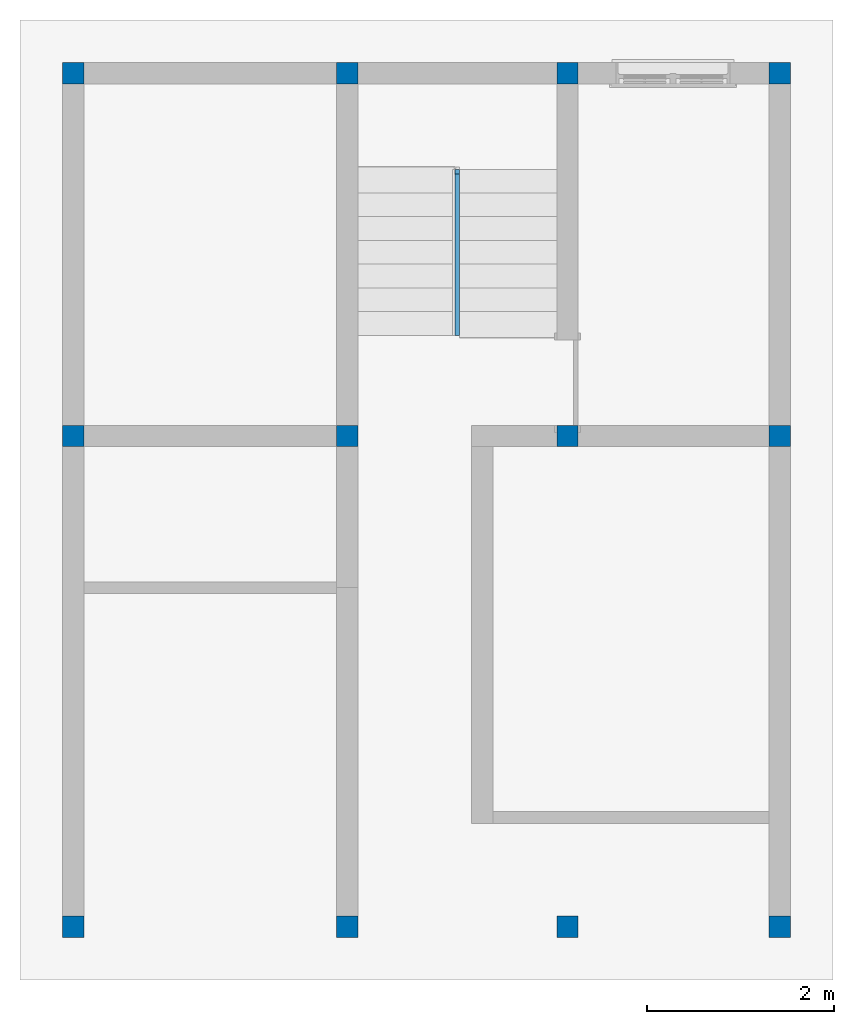
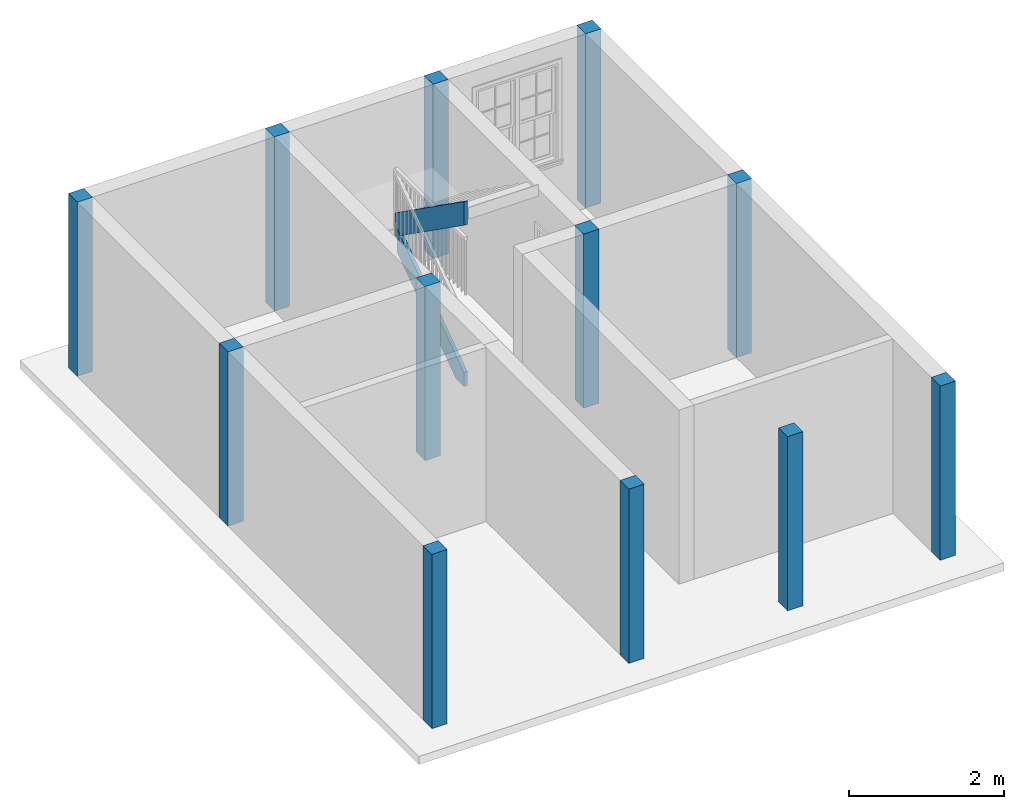
# One storey, part 1 of 6: 12 columns, 2 members, 1 element without a shape of its own.
"""IFC2X3 building model written with IfcOpenShell, lengths in feet."""

from ifc_helpers import new_model, entity, si_unit, converted_unit, derived_unit, direction, frame, origin, origin_2d_with_axis, place, context, subcontext, project, spatial, polyline, rectangle, outline, extrude, source, transform, mapped, material, type_object, type_shapes, element, aggregate, save


model = new_model("IFC2X3")

# Units and contexts
model_context = context("Model", 3, precision=0.0001, world=origin(), true_north=direction((6.123031769111886e-17, 1.0)))
body_context = subcontext(model_context, "Body", "Model", "MODEL_VIEW")
ifc_project = project(units=[converted_unit("LENGTHUNIT", "FOOT", entity("IfcLengthMeasure", 0.3048), si_unit("LENGTHUNIT", "METRE"), dimensions=[1, 0, 0, 0, 0, 0, 0]), converted_unit("AREAUNIT", "SQUARE FOOT", entity("IfcAreaMeasure", 0.09290304), si_unit("AREAUNIT", "SQUARE_METRE"), dimensions=[2, 0, 0, 0, 0, 0, 0]), converted_unit("VOLUMEUNIT", "CUBIC FOOT", entity("IfcVolumeMeasure", 0.028316846592000004), si_unit("VOLUMEUNIT", "CUBIC_METRE"), dimensions=[3, 0, 0, 0, 0, 0, 0]), converted_unit("PLANEANGLEUNIT", "DEGREE", entity("IfcPlaneAngleMeasure", 0.017453292519943278), si_unit("PLANEANGLEUNIT", "RADIAN"), dimensions=[0, 0, 0, 0, 0, 0, 0]), si_unit("MASSUNIT", "GRAM", prefix="KILO"), derived_unit("MASSDENSITYUNIT", [(si_unit("MASSUNIT", "GRAM", prefix="KILO"), 1), (si_unit("LENGTHUNIT", "METRE"), -3)]), derived_unit("IONCONCENTRATIONUNIT", [(si_unit("MASSUNIT", "GRAM", prefix="KILO"), 1), (si_unit("LENGTHUNIT", "METRE"), -3)]), derived_unit("MOMENTOFINERTIAUNIT", [(si_unit("LENGTHUNIT", "METRE"), 4)]), si_unit("TIMEUNIT", "SECOND"), si_unit("FREQUENCYUNIT", "HERTZ"), si_unit("THERMODYNAMICTEMPERATUREUNIT", "DEGREE_CELSIUS"), derived_unit("THERMALTRANSMITTANCEUNIT", [(si_unit("MASSUNIT", "GRAM", prefix="KILO"), 1), (si_unit("THERMODYNAMICTEMPERATUREUNIT", "KELVIN"), -1), (si_unit("TIMEUNIT", "SECOND"), -3)]), derived_unit("THERMALCONDUCTANCEUNIT", [(si_unit("MASSUNIT", "GRAM", prefix="KILO"), 1), (si_unit("THERMODYNAMICTEMPERATUREUNIT", "KELVIN"), -1), (si_unit("TIMEUNIT", "SECOND"), -3), (si_unit("LENGTHUNIT", "METRE"), 1)]), derived_unit("VOLUMETRICFLOWRATEUNIT", [(si_unit("LENGTHUNIT", "METRE"), 3), (si_unit("TIMEUNIT", "SECOND"), -1)]), derived_unit("MASSFLOWRATEUNIT", [(si_unit("MASSUNIT", "GRAM", prefix="KILO"), 1), (si_unit("TIMEUNIT", "SECOND"), -1)]), derived_unit("ROTATIONALFREQUENCYUNIT", [(si_unit("TIMEUNIT", "SECOND"), -1)]), si_unit("ELECTRICCURRENTUNIT", "AMPERE"), si_unit("ELECTRICVOLTAGEUNIT", "VOLT"), si_unit("POWERUNIT", "WATT"), converted_unit("FORCEUNIT", "KIP", entity("IfcForceMeasure", 2.088543423315013e-05), si_unit("FORCEUNIT", "NEWTON"), dimensions=[1, 1, -2, 0, 0, 0, 0]), si_unit("ILLUMINANCEUNIT", "LUX"), si_unit("LUMINOUSFLUXUNIT", "LUMEN"), si_unit("LUMINOUSINTENSITYUNIT", "CANDELA"), si_unit("ENERGYUNIT", "JOULE"), derived_unit("USERDEFINED", [(si_unit("MASSUNIT", "GRAM", prefix="KILO"), -1), (si_unit("LENGTHUNIT", "METRE"), -2), (si_unit("TIMEUNIT", "SECOND"), 3), (si_unit("LUMINOUSFLUXUNIT", "LUMEN"), 1)]), derived_unit("USERDEFINED", [(si_unit("MASSUNIT", "GRAM", prefix="KILO"), 1), (si_unit("TIMEUNIT", "SECOND"), -3), (si_unit("LENGTHUNIT", "METRE"), 3), (si_unit("ELECTRICCURRENTUNIT", "AMPERE"), -2)]), derived_unit("SOUNDPOWERUNIT", [(si_unit("MASSUNIT", "GRAM", prefix="KILO"), 1), (si_unit("TIMEUNIT", "SECOND"), -3), (si_unit("LENGTHUNIT", "METRE"), 2)]), derived_unit("SOUNDPRESSUREUNIT", [(si_unit("MASSUNIT", "GRAM", prefix="KILO"), 1), (si_unit("LENGTHUNIT", "METRE"), -1), (si_unit("TIMEUNIT", "SECOND"), -2)]), derived_unit("LINEARVELOCITYUNIT", [(si_unit("LENGTHUNIT", "METRE"), 1), (si_unit("TIMEUNIT", "SECOND"), -1)]), si_unit("PRESSUREUNIT", "PASCAL"), derived_unit("USERDEFINED", [(si_unit("MASSUNIT", "GRAM", prefix="KILO"), 1), (si_unit("LENGTHUNIT", "METRE"), -2), (si_unit("TIMEUNIT", "SECOND"), -2)]), derived_unit("LINEARFORCEUNIT", [(si_unit("MASSUNIT", "GRAM", prefix="KILO"), 1), (si_unit("TIMEUNIT", "SECOND"), -2)]), derived_unit("PLANARFORCEUNIT", [(si_unit("MASSUNIT", "GRAM", prefix="KILO"), 1), (si_unit("LENGTHUNIT", "METRE"), -1), (si_unit("TIMEUNIT", "SECOND"), -2)]), derived_unit("SPECIFICHEATCAPACITYUNIT", [(si_unit("THERMODYNAMICTEMPERATUREUNIT", "KELVIN"), -1), (si_unit("LENGTHUNIT", "METRE"), 2), (si_unit("TIMEUNIT", "SECOND"), -2)]), derived_unit("HEATFLUXDENSITYUNIT", [(si_unit("MASSUNIT", "GRAM", prefix="KILO"), 1), (si_unit("TIMEUNIT", "SECOND"), -3)]), derived_unit("HEATINGVALUEUNIT", [(si_unit("LENGTHUNIT", "METRE"), 2), (si_unit("TIMEUNIT", "SECOND"), -2)]), derived_unit("VAPORPERMEABILITYUNIT", [(si_unit("LENGTHUNIT", "METRE"), -1), (si_unit("TIMEUNIT", "SECOND"), 1)]), derived_unit("DYNAMICVISCOSITYUNIT", [(si_unit("MASSUNIT", "GRAM", prefix="KILO"), 1), (si_unit("TIMEUNIT", "SECOND"), -1), (si_unit("LENGTHUNIT", "METRE"), -1)]), derived_unit("THERMALEXPANSIONCOEFFICIENTUNIT", [(si_unit("THERMODYNAMICTEMPERATUREUNIT", "KELVIN"), -1)]), derived_unit("MODULUSOFELASTICITYUNIT", [(si_unit("MASSUNIT", "GRAM", prefix="KILO"), 1), (si_unit("LENGTHUNIT", "METRE"), -1), (si_unit("TIMEUNIT", "SECOND"), -2)]), derived_unit("ISOTHERMALMOISTURECAPACITYUNIT", [(si_unit("LENGTHUNIT", "METRE"), 3), (si_unit("MASSUNIT", "GRAM", prefix="KILO"), -1)]), derived_unit("MOISTUREDIFFUSIVITYUNIT", [(si_unit("TIMEUNIT", "SECOND"), -1), (si_unit("LENGTHUNIT", "METRE"), 2)]), derived_unit("MASSPERLENGTHUNIT", [(si_unit("MASSUNIT", "GRAM", prefix="KILO"), 1), (si_unit("LENGTHUNIT", "METRE"), -1)]), derived_unit("THERMALRESISTANCEUNIT", [(si_unit("MASSUNIT", "GRAM", prefix="KILO"), -1), (si_unit("TIMEUNIT", "SECOND"), 3), (si_unit("THERMODYNAMICTEMPERATUREUNIT", "KELVIN"), 1)]), derived_unit("ACCELERATIONUNIT", [(si_unit("LENGTHUNIT", "METRE"), 1), (si_unit("TIMEUNIT", "SECOND"), -2)]), derived_unit("ANGULARVELOCITYUNIT", [(si_unit("TIMEUNIT", "SECOND"), -1), (si_unit("PLANEANGLEUNIT", "RADIAN"), 1)]), derived_unit("LINEARSTIFFNESSUNIT", [(si_unit("MASSUNIT", "GRAM", prefix="KILO"), 1), (si_unit("TIMEUNIT", "SECOND"), -2)]), derived_unit("WARPINGCONSTANTUNIT", [(si_unit("LENGTHUNIT", "METRE"), 6)]), derived_unit("LINEARMOMENTUNIT", [(si_unit("MASSUNIT", "GRAM", prefix="KILO"), 1), (si_unit("LENGTHUNIT", "METRE"), 1), (si_unit("TIMEUNIT", "SECOND"), -2)]), derived_unit("TORQUEUNIT", [(si_unit("MASSUNIT", "GRAM", prefix="KILO"), 1), (si_unit("LENGTHUNIT", "METRE"), 2), (si_unit("TIMEUNIT", "SECOND"), -2)])], contexts=[model_context])

# Site, building, storey
site_placement = place(None, origin())
site = spatial("IfcSite", under=ifc_project, at=site_placement, CompositionType="ELEMENT")
building_placement = place(site_placement, origin())
building = spatial("IfcBuilding", under=site, at=building_placement, CompositionType="ELEMENT")
storey_placement = place(building_placement, origin())
storey = spatial("IfcBuildingStorey", under=building, at=storey_placement, Name="Level 1", CompositionType="ELEMENT", Elevation=0.0)

# Columns
ifc_material_1 = material(Name="Concrete, Cast-in-Place gray")
column_type = type_object("IfcColumnType", PredefinedType="COLUMN", material=ifc_material_1)
shared_shape = source(origin(), body_context, "Body", "SweptSolid", [
    extrude(rectangle(XDim=0.7499999999999999, YDim=0.7499999999999999, at=origin_2d_with_axis()), frame((0.0, 0.0, 0.0), z_axis=(0.0, 0.0, 1.0), x_axis=(-1.0, 0.0, 0.0)), (0.0, 0.0, 1.0), 9.0),
])
type_shapes(column_type, [shared_shape])
for number, where in (
    (1, (-16.534913085251212, -13.62441970192868, 0.0)),
    (2, (-16.534913085251183, 3.625580298071295, 0.0)),
    (3, (-16.534913085251162, 16.375580298071327, 0.0)),
    (4, (-6.909913085251211, -13.624419701928709, 0.0)),
    (5, (-6.909913085251183, 3.625580298071263, 0.0)),
    (6, (-6.909913085251163, 16.375580298071295, 0.0)),
    (7, (0.8400869147487888, -13.624419701928737, 0.0)),
    (8, (0.8400869147488167, 3.625580298071238, 0.0)),
    (9, (0.8400869147488372, 16.37558029807127, 0.0)),
    (10, (8.298420248082161, -13.624419701928758, 0.0)),
    (11, (8.29842024808219, 3.6255802980712133, 0.0)),
    (12, (8.29842024808221, 16.375580298071245, 0.0)),
):
    element("IfcColumn", number, at=place(storey_placement, frame(where)), inside=storey, type_object=column_type, material=ifc_material_1, context=body_context, shape_type="MappedRepresentation", body=[
        mapped(shared_shape, transform((0.0, 0.0, 0.0), scale=1.0)),
    ])

# Stair, members
type_product = type_object("IfcTypeProduct")
stair_placement = place(storey_placement, origin())
stair = element("IfcStair", 13, at=stair_placement, inside=storey, type_object=type_product, Name="Assembled Stair:Stair", ShapeType="HALF_TURN_STAIR")
ifc_material_2 = material()
member_type = type_object("IfcMemberType", PredefinedType="STRINGER")
member_1_placement = place(stair_placement, origin())
member_1 = element("IfcMember", 14, at=member_1_placement, type_object=member_type, material=ifc_material_2, Name="Assembled Stair:Stair:385185 Stringer 1", context=body_context, shape_type="SweptSolid", body=[
    extrude(outline(polyline([(-2.4069248028562225, -1.7933615706472712), (-1.7056341219084468, -1.7933615706472712), (3.2597418638104454, 1.7134352192673155), (3.2597418638104454, 2.9376856276806333), (-2.4069248028562225, -1.0643977056534073), (-2.4069248028562225, -1.7933615706472712)])), frame((-3.118246418584473, 9.574171767594548, 1.7933615706472712), z_axis=(1.0, 0.0, 0.0), x_axis=(0.0, 1.0, 0.0)), (0.0, 0.0, 1.0), 0.16666666666666652),
])
member_2_placement = place(stair_placement, origin())
member_2 = element("IfcMember", 15, at=member_2_placement, type_object=member_type, material=ifc_material_2, Name="Assembled Stair:Stair:385185 Stringer 2", context=body_context, shape_type="SweptSolid", body=[
    extrude(outline(polyline([(-3.217605357872113, -0.5), (3.9238553578722404, -0.5), (3.217605357872115, 0.5000000000000002), (-3.923855357872238, 0.49999999999999956), (-3.217605357872113, -0.5)])), frame((-3.118246418584472, 10.083913631404993, 6.885067827455071), z_axis=(1.0, 0.0, 0.0), x_axis=(0.0, -0.8168263560524708, 0.5768836139621598)), (0.0, 0.0, 1.0), 0.16666666666666652),
])
aggregate(stair, [member_1, member_2])

save(model, "model.ifc")
